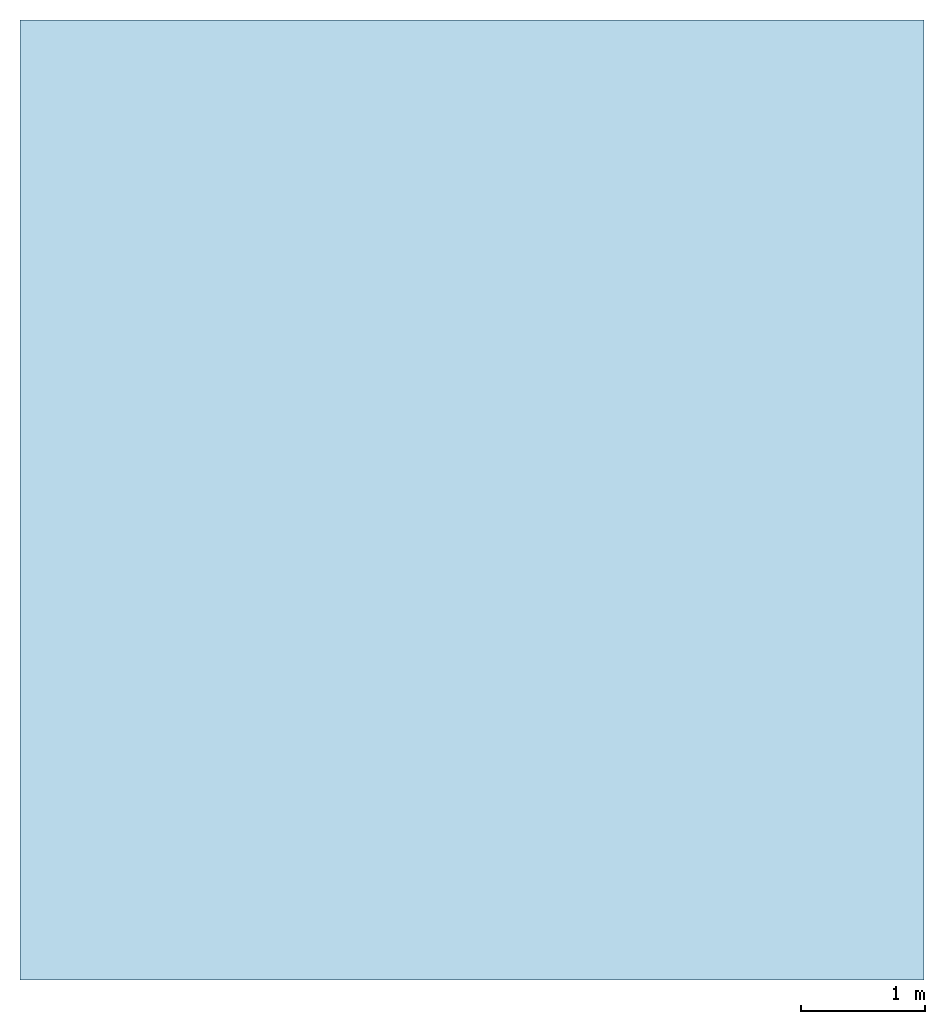
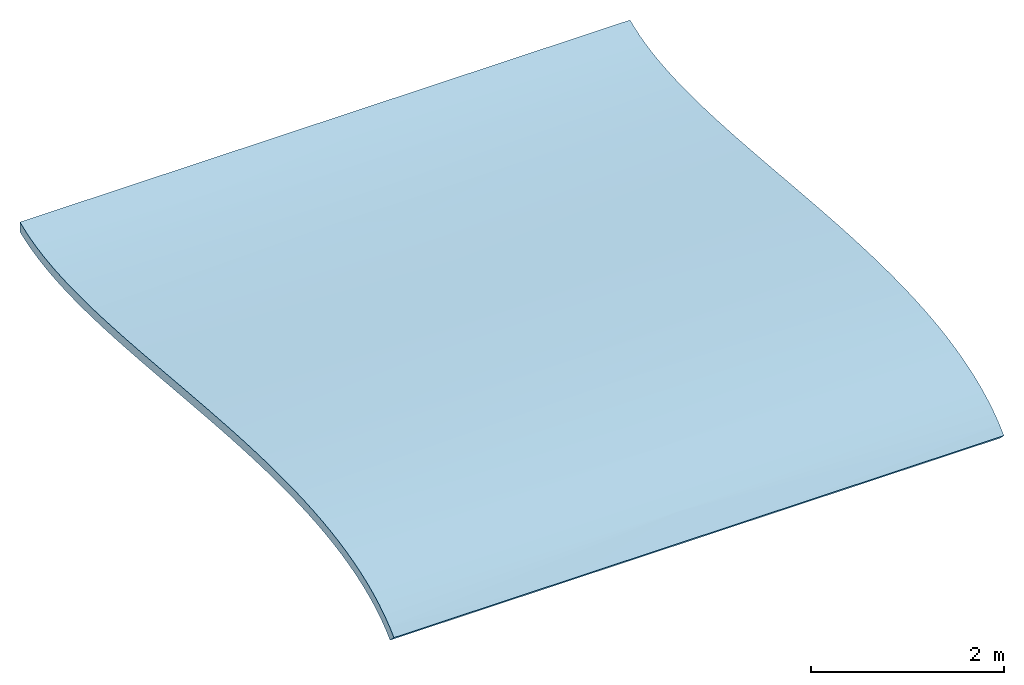
# One storey: 1 roof.
"""IFC2X3 building model written with IfcOpenShell, lengths in millimetres."""

from ifc_helpers import new_model, entity, si_unit, converted_unit, derived_unit, direction, frame, origin, place, context, subcontext, project, spatial, faceted_brep, material, element, save


model = new_model("IFC2X3")

# Units and contexts
model_context = context("Model", 3, precision=0.01, world=origin(), true_north=direction((6.12303176911189e-17, 1.0)))
body_context = subcontext(model_context, "Body", "Model", "MODEL_VIEW")
ifc_project = project(units=[si_unit("LENGTHUNIT", "METRE", prefix="MILLI"), si_unit("AREAUNIT", "SQUARE_METRE"), si_unit("VOLUMEUNIT", "CUBIC_METRE"), converted_unit("PLANEANGLEUNIT", "DEGREE", entity("IfcRatioMeasure", 0.0174532925199433), si_unit("PLANEANGLEUNIT", "RADIAN"), dimensions=[0, 0, 0, 0, 0, 0, 0]), si_unit("MASSUNIT", "GRAM", prefix="KILO"), si_unit("TIMEUNIT", "SECOND"), si_unit("FREQUENCYUNIT", "HERTZ"), si_unit("THERMODYNAMICTEMPERATUREUNIT", "DEGREE_CELSIUS"), derived_unit("THERMALTRANSMITTANCEUNIT", [(si_unit("MASSUNIT", "GRAM", prefix="KILO"), 1), (si_unit("THERMODYNAMICTEMPERATUREUNIT", "KELVIN"), -1), (si_unit("TIMEUNIT", "SECOND"), -3)]), derived_unit("VOLUMETRICFLOWRATEUNIT", [(si_unit("LENGTHUNIT", "METRE"), 3), (si_unit("TIMEUNIT", "SECOND"), -1)]), si_unit("ELECTRICCURRENTUNIT", "AMPERE"), si_unit("ELECTRICVOLTAGEUNIT", "VOLT"), si_unit("POWERUNIT", "WATT"), si_unit("FORCEUNIT", "NEWTON", prefix="KILO"), si_unit("ILLUMINANCEUNIT", "LUX"), si_unit("LUMINOUSFLUXUNIT", "LUMEN"), si_unit("LUMINOUSINTENSITYUNIT", "CANDELA"), derived_unit("USERDEFINED", [(si_unit("MASSUNIT", "GRAM", prefix="KILO"), -1), (si_unit("LENGTHUNIT", "METRE"), -2), (si_unit("TIMEUNIT", "SECOND"), 3), (si_unit("LUMINOUSFLUXUNIT", "LUMEN"), 1)]), derived_unit("LINEARVELOCITYUNIT", [(si_unit("LENGTHUNIT", "METRE"), 1), (si_unit("TIMEUNIT", "SECOND"), -1)]), si_unit("PRESSUREUNIT", "PASCAL"), derived_unit("USERDEFINED", [(si_unit("LENGTHUNIT", "METRE"), -2), (si_unit("MASSUNIT", "GRAM", prefix="KILO"), 1), (si_unit("TIMEUNIT", "SECOND"), -2)])], contexts=[model_context])

# Site, building, storey
site_placement = place(None, origin())
site = spatial("IfcSite", under=ifc_project, at=site_placement, CompositionType="ELEMENT")
building_placement = place(site_placement, origin())
building = spatial("IfcBuilding", under=site, at=building_placement, CompositionType="ELEMENT")
storey_placement = place(building_placement, frame((0.0, 0.0, 4000.0)))
storey = spatial("IfcBuildingStorey", under=building, at=storey_placement, Name="Level 1", CompositionType="ELEMENT", Elevation=4000.0)

# Roof
ifc_material = material(Name="Roofing, Standing Seam")
roof_placement = place(storey_placement, frame((6902.64559519151, -4029.3346626259, -2084.22174702)))
element("IfcRoof", 1, at=roof_placement, inside=storey, material=ifc_material, ShapeType="NOTDEFINED", context=body_context, shape_type="Brep", body=[
    faceted_brep([(7290.0, 5515.8367599344, 493.394615891995), (7290.0, 5326.79971379529, 507.350489187514), (7290.0, 5134.90988298857, 522.577872454902), (7290.0, 4940.56039759163, 538.776818324134), (7290.0, 4744.14438768187, 555.647379425186), (7290.0, 4546.05498333669, 572.889608388034), (7290.0, 4346.68531463349, 590.203557842651), (7290.0, 4146.42851164965, 607.289280419015), (7290.0, 3945.67770446258, 623.846828747097), (7290.0, 3744.82602314968, 639.576255456876), (7290.0, 3544.26659778834, 654.177613178324), (7290.0, 3344.39255845596, 667.350954541419), (7290.0, 3145.59703522994, 678.796332176132), (7290.0, 2948.27315818768, 688.213798712443), (7290.0, 2752.81405740656, 695.303406780325), (7290.0, 2559.61286296399, 699.765209009751), (7290.0, 2369.06270493737, 701.299258030699), (7290.0, 2181.55671340408, 699.605606473143), (7290.0, 1997.48801844154, 694.384306967057), (7290.0, 1817.24975012714, 685.335412142419), (7290.0, 1641.23503853826, 672.1589746292), (7290.0, 1469.83701375232, 654.555047057379), (7290.0, 1303.44880584671, 632.223682056929), (7290.0, 1142.46354489882, 604.864932257825), (7290.0, 987.274360986045, 572.178850290043), (7290.0, 838.274384185795, 533.865488783557), (7290.0, 695.856744575461, 489.624900368343), (7290.0, 560.414572232438, 439.157137674376), (7290.0, 432.340997234126, 382.16225333163), (7290.0, 312.029149657921, 318.340299970082), (7290.0, 199.87215958122, 247.391330219706), (7290.0, 96.2631570814181, 169.015396710476), (7290.0, 1.59527223591536, 82.9125520723694), (7290.0, 82.9125520723667, 1.59527223591644), (7290.0, 174.910983430362, 84.8106413142446), (7290.0, 276.870078001889, 160.732287026324), (7290.0, 388.608164668871, 229.627760435748), (7290.0, 509.856659043408, 291.700233714452), (7290.0, 640.265006553385, 347.128372768542), (7290.0, 779.417409593224, 396.093969562423), (7290.0, 926.852331926818, 438.797089949555), (7290.0, 1082.079622683, 475.46195964892), (7290.0, 1244.59347115748, 506.337245264513), (7290.0, 1413.8812661407, 531.693556891933), (7290.0, 1589.42918286418, 551.819949919396), (7290.0, 1770.72543261784, 567.020383280753), (7290.0, 1957.26196426142, 577.610566329318), (7290.0, 2148.53520002354, 583.915333002722), (7290.0, 2344.04620233902, 586.266539454875), (7290.0, 2543.30053061132, 585.001416438763), (7290.0, 2745.80794324389, 580.46130577549), (7290.0, 2951.08212696384, 572.990675875639), (7290.0, 3158.63987988746, 562.936400057024), (7290.0, 3368.00056105001, 550.646731588187), (7290.0, 3578.68943782287, 536.472643248029), (7290.0, 3790.23289787507, 520.765623469924), (7290.0, 4002.1573757589, 503.877174054427), (7290.0, 4213.99265493133, 486.159751629483), (7290.0, 4425.27404377407, 467.96738806927), (7290.0, 4635.53736724828, 449.6542625332), (7290.0, 4844.31869207961, 431.574600983515), (7290.0, 5051.15896875634, 414.08357482278), (7290.0, 5255.60368271807, 397.537233368033), (7290.0, 5457.19849128652, 382.291659210715), (7290.0, 5655.49034587235, 368.703392642995), (7290.0, 5850.03758452909, 357.13300124958), (7290.0, 6040.4044608883, 347.943144870431), (7290.0, 6226.1552790644, 341.496501200568), (7290.0, 6406.85837974509, 338.158011573538), (7290.0, 6582.10003525807, 338.302673420665), (7290.0, 6751.47451000516, 342.31103492595), (7290.0, 6914.58904090166, 350.575753809645), (7290.0, 7071.06630490577, 363.506025200245), (7290.0, 7220.54613217014, 381.535486437245), (7290.0, 7362.68547363244, 405.133111431908), (7290.0, 7497.15423732193, 434.818313729678), (7290.0, 7623.62222011881, 471.18003034358), (7290.0, 7741.72983927739, 514.896982003152), (7290.0, 7741.72983927739, 640.601924700541), (7290.0, 7642.66017244013, 599.491464015022), (7290.0, 7534.84076977431, 564.151723851747), (7290.0, 7418.66476135731, 534.282756840691), (7290.0, 7294.52527726654, 509.584615611828), (7290.0, 7162.81544757938, 489.757352795134), (7290.0, 7023.92840237325, 474.501021020584), (7290.0, 6878.25727172553, 463.515672918153), (7290.0, 6726.19518571363, 456.501361117816), (7290.0, 6568.13527441493, 453.158138249548), (7290.0, 6404.47066790685, 453.186056943324), (7290.0, 6235.59449626676, 456.285169829119), (7290.0, 6061.89988957208, 462.155529536909), (7290.0, 5883.77997790019, 470.497188696669), (7290.0, 5701.6278913285, 481.010199938372), (0.0, 174.910983430373, 84.8106413142446), (0.0, 82.912552072378, 1.59527223591644), (0.0, 1.59527223592673, 82.9125520723694), (0.0, 96.2631570814294, 169.015396710476), (0.0, 199.872159581231, 247.391330219706), (0.0, 312.029149657932, 318.340299970082), (0.0, 432.340997234137, 382.16225333163), (0.0, 560.41457223245, 439.157137674376), (0.0, 695.856744575472, 489.624900368343), (0.0, 838.274384185806, 533.865488783557), (0.0, 987.274360986057, 572.178850290043), (0.0, 1142.46354489883, 604.864932257825), (0.0, 1303.44880584672, 632.223682056929), (0.0, 1469.83701375233, 654.555047057379), (0.0, 1641.23503853827, 672.1589746292), (0.0, 1817.24975012715, 685.335412142419), (0.0, 1997.48801844155, 694.384306967057), (0.0, 2181.55671340409, 699.605606473143), (0.0, 2369.06270493738, 701.299258030699), (0.0, 2559.612862964, 699.765209009751), (0.0, 2752.81405740657, 695.303406780325), (0.0, 2948.27315818769, 688.213798712443), (0.0, 3145.59703522995, 678.796332176132), (0.0, 3344.39255845598, 667.350954541419), (0.0, 3544.26659778835, 654.177613178324), (0.0, 3744.82602314969, 639.576255456876), (0.0, 3945.67770446259, 623.846828747097), (0.0, 4146.42851164966, 607.289280419015), (0.0, 4346.6853146335, 590.203557842651), (0.0, 4546.0549833367, 572.889608388034), (0.0, 4744.14438768188, 555.647379425186), (0.0, 4940.56039759164, 538.776818324134), (0.0, 5134.90988298858, 522.577872454902), (0.0, 5326.79971379531, 507.350489187514), (0.0, 5515.83675993441, 493.394615891995), (0.0, 5701.62789132851, 481.010199938372), (0.0, 5883.7799779002, 470.497188696669), (0.0, 6061.89988957209, 462.155529536909), (0.0, 6235.59449626677, 456.285169829119), (0.0, 6404.47066790686, 453.186056943324), (0.0, 6568.13527441495, 453.158138249548), (0.0, 6726.19518571364, 456.501361117816), (0.0, 6878.25727172555, 463.515672918153), (0.0, 7023.92840237326, 474.501021020584), (0.0, 7162.8154475794, 489.757352795134), (0.0, 7294.52527726655, 509.584615611828), (0.0, 7418.66476135732, 534.282756840691), (0.0, 7534.84076977432, 564.151723851747), (0.0, 7642.66017244015, 599.491464015022), (0.0, 7741.7298392774, 640.601924700541), (0.0, 7741.7298392774, 514.896982003152), (0.0, 7623.62222011882, 471.18003034358), (0.0, 7497.15423732194, 434.818313729678), (0.0, 7362.68547363246, 405.133111431908), (0.0, 7220.54613217015, 381.535486437245), (0.0, 7071.06630490578, 363.506025200245), (0.0, 6914.58904090168, 350.575753809645), (0.0, 6751.47451000517, 342.31103492595), (0.0, 6582.10003525808, 338.302673420665), (0.0, 6406.8583797451, 338.158011573538), (0.0, 6226.15527906442, 341.496501200568), (0.0, 6040.40446088831, 347.943144870431), (0.0, 5850.0375845291, 357.13300124958), (0.0, 5655.49034587236, 368.703392642995), (0.0, 5457.19849128653, 382.291659210715), (0.0, 5255.60368271808, 397.537233368033), (0.0, 5051.15896875636, 414.08357482278), (0.0, 4844.31869207963, 431.574600983515), (0.0, 4635.53736724829, 449.654262533201), (0.0, 4425.27404377408, 467.96738806927), (0.0, 4213.99265493135, 486.159751629483), (0.0, 4002.15737575891, 503.877174054427), (0.0, 3790.23289787508, 520.765623469924), (0.0, 3578.68943782288, 536.472643248029), (0.0, 3368.00056105003, 550.646731588187), (0.0, 3158.63987988748, 562.936400057024), (0.0, 2951.08212696385, 572.990675875639), (0.0, 2745.80794324391, 580.46130577549), (0.0, 2543.30053061133, 585.001416438763), (0.0, 2344.04620233903, 586.266539454875), (0.0, 2148.53520002355, 583.915333002722), (0.0, 1957.26196426143, 577.610566329318), (0.0, 1770.72543261785, 567.020383280753), (0.0, 1589.42918286419, 551.819949919396), (0.0, 1413.88126614072, 531.693556891933), (0.0, 1244.59347115749, 506.337245264513), (0.0, 1082.07962268301, 475.46195964892), (0.0, 926.852331926829, 438.797089949555), (0.0, 779.417409593235, 396.093969562423), (0.0, 640.265006553396, 347.128372768542), (0.0, 509.856659043419, 291.700233714452), (0.0, 388.608164668882, 229.627760435748), (0.0, 276.870078001901, 160.732287026324), (3644.99993293393, 7094.24445769617, 481.576561905731), (4873.42643812675, 3553.80531263484, 653.512268049968), (4873.4264349205, 2378.07126114901, 701.297023002409), (4873.42644526128, 6885.34251186391, 463.946393367723), (3645.0, 6647.89036821082, 454.389609869361), (4833.14712739967, 2948.2731567139, 688.213798774734), (4866.99006258193, 437.319117905568, 384.571897066555), (2456.85285398539, 6878.2572394437, 463.515670978227), (5143.13104624073, 1728.68987856066, 679.281882891266), (5143.13108979598, 6320.65944870228, 454.370460977534), (3755.78478848222, 7477.77282685478, 548.552154853789), (4873.42644037187, 4155.97956112262, 606.485217518944), (4154.34922870835, 7741.72983927739, 640.601924700541), (2077.17461435418, 7741.7298392774, 640.601924700541), (4158.30513321711, 7293.47192435091, 509.402015403087), (2083.10604010014, 7357.56586274999, 521.306075659749), (3645.0, 5973.36851791904, 466.03619378561), (2879.75484514576, 6320.65944357094, 454.370461072072), (3645.0, 5038.01802242677, 530.574647113318), (4873.42644326935, 4753.53927521058, 554.833156981952), (3645.0, 4446.50560851197, 581.556365015466), (2456.85288603018, 4744.14438460476, 555.647379691955), (3645.0, 3845.23990030763, 631.833804182173), (3705.40861769169, 5515.83675357721, 493.394616340274), (2456.85288047229, 4146.42850943027, 607.289280605706), (2083.10611478902, 7589.81964531163, 581.119009704308), (3645.0, 3244.83541008503, 673.308385628513), (3645.0, 2089.06813226758, 697.454659397298), (3645.0, 2655.90665002507, 697.88153036414), (3645.0, 627.239153951746, 465.188162362641), (3645.0, 1385.99211138934, 643.999040856456), (2443.55129102401, 434.296109138398, 383.110638627745), (3561.38047398335, 254.906726379767, 283.775438586921), (4154.34866312986, 1.59527223592023, 82.9125520723689), (3705.40870996265, 987.274360445025, 572.178850163996), (2456.8528697884, 2369.06270397232, 701.299258030547), (2456.8528761003, 3544.26659613439, 654.177613293421), (2879.75477886344, 1728.68987835546, 679.28188287592), (2416.57356343063, 2938.91950082385, 688.606588632029), (2077.17433156493, 1.59527223592348, 82.9125520723689), (2063.72518347873, 82.9125520723753, 1.59527223591536), (4127.45036695744, 82.9125520723726, 1.59527223591482), (3644.9999788372, 852.129705162649, 418.214959644609), (3645.0, 5153.70916869194, 405.67006324816), (2527.73964691474, 1082.07964281491, 475.461963920434), (3645.0, 1328.42277286879, 519.687632279817), (4908.86982804358, 1057.38503155373, 470.13294026234), (3645.0, 4108.11524259923, 495.099966522061), (3645.0, 5753.2592804111, 362.643297370898), (3644.99968743525, 448.06389055526, 261.505584802579), (5014.79117722024, 224.654963164434, 123.664570221709), (2617.32967391422, 224.654968225618, 123.66457398959), (3645.0, 3473.20857833004, 543.773271701596), (4908.86981738276, 3126.14787253684, 564.65996733546), (4762.26032903465, 640.265053007929, 347.128390738387), (3645.0, 2848.12943127412, 577.070656466003), (3645.0, 1863.37025447432, 572.871646434587), (4908.86982958123, 1561.66752542892, 549.01395190956), (2527.7396350338, 3158.6398826696, 562.936399907201), (3645.0, 2361.25902041309, 586.295229736864), (2527.73965785907, 1589.42919219338, 551.819950839825), (4908.86981441765, 3757.21313088441, 523.301229060313), (2063.72490335407, 7741.7298392774, 514.896982003151), (4127.44980670813, 7741.72983927739, 514.896982003152), (2617.32977762103, 7561.40952052499, 452.124720828273), (2381.13004015164, 661.396844690464, 355.183267158089), (4908.86980929022, 5425.97285046491, 384.568668097563), (4908.86980800386, 6011.01621100343, 349.20466139658), (3645.0, 7146.70272357588, 371.855063208914), (3645.0, 6317.1639638328, 339.415474239967), (2538.13047883346, 7350.35431830495, 402.796681929502), (4770.28662975967, 7430.89904212718, 419.179976333053), (2527.73962910166, 3790.23289988587, 520.76562331465), (2527.73961877477, 5457.19849223257, 382.291659142245), (2527.73961617756, 6040.40446161021, 347.943144840199), (3645.0, 4653.78727024394, 448.065185016509), (3645.0, 6765.93576440861, 342.855882859757)], [[[0, 1, 2, 3, 4, 5, 6, 7, 8, 9, 10, 11, 12, 13, 14, 15, 16, 17, 18, 19, 20, 21, 22, 23, 24, 25, 26, 27, 28, 29, 30, 31, 32, 33, 34, 35, 36, 37, 38, 39, 40, 41, 42, 43, 44, 45, 46, 47, 48, 49, 50, 51, 52, 53, 54, 55, 56, 57, 58, 59, 60, 61, 62, 63, 64, 65, 66, 67, 68, 69, 70, 71, 72, 73, 74, 75, 76, 77, 78, 79, 80, 81, 82, 83, 84, 85, 86, 87, 88, 89, 90, 91, 92]], [[93, 94, 95, 96, 97, 98, 99, 100, 101, 102, 103, 104, 105, 106, 107, 108, 109, 110, 111, 112, 113, 114, 115, 116, 117, 118, 119, 120, 121, 122, 123, 124, 125, 126, 127, 128, 129, 130, 131, 132, 133, 134, 135, 136, 137, 138, 139, 140, 141, 142, 143, 144, 145, 146, 147, 148, 149, 150, 151, 152, 153, 154, 155, 156, 157, 158, 159, 160, 161, 162, 163, 164, 165, 166, 167, 168, 169, 170, 171, 172, 173, 174, 175, 176, 177, 178, 179, 180, 181, 182, 183, 184, 185]], [[186, 84, 83]], [[10, 9, 187]], [[16, 15, 188]], [[189, 190, 86]], [[87, 86, 190]], [[191, 13, 12]], [[28, 27, 192]], [[193, 190, 189]], [[19, 18, 194]], [[88, 195, 89]], [[80, 196, 81]], [[7, 6, 197]], [[190, 134, 133]], [[196, 79, 198]], [[186, 137, 136]], [[198, 79, 78]], [[142, 141, 199]], [[200, 186, 83]], [[201, 186, 200]], [[91, 202, 92]], [[138, 201, 139]], [[202, 195, 203]], [[204, 3, 2]], [[5, 205, 206]], [[206, 6, 5]], [[206, 205, 207]], [[208, 8, 197]], [[202, 91, 90]], [[0, 92, 209]], [[128, 127, 209]], [[1, 209, 204]], [[92, 202, 209]], [[2, 1, 204]], [[202, 90, 195]], [[197, 210, 208]], [[204, 125, 124]], [[80, 79, 196]], [[211, 199, 141]], [[88, 87, 195]], [[4, 3, 205]], [[140, 211, 141]], [[211, 140, 139]], [[85, 84, 189]], [[201, 196, 211]], [[206, 122, 121]], [[193, 186, 136]], [[137, 201, 138]], [[208, 119, 118]], [[202, 130, 129]], [[135, 193, 136]], [[193, 135, 134]], [[212, 116, 115]], [[213, 110, 109]], [[133, 203, 190]], [[214, 113, 112]], [[203, 133, 132]], [[215, 101, 100]], [[131, 203, 132]], [[131, 130, 203]], [[216, 106, 105]], [[196, 200, 81]], [[129, 128, 202]], [[128, 209, 202]], [[217, 99, 98]], [[201, 211, 139]], [[200, 82, 81]], [[126, 209, 127]], [[0, 209, 1]], [[126, 125, 204]], [[186, 201, 137]], [[196, 201, 200]], [[207, 204, 124]], [[207, 124, 123]], [[218, 97, 96]], [[211, 196, 198]], [[122, 207, 123]], [[121, 210, 206]], [[29, 218, 30]], [[121, 120, 210]], [[218, 219, 31]], [[8, 208, 9]], [[15, 14, 214]], [[29, 28, 192]], [[215, 192, 27]], [[188, 213, 17]], [[18, 17, 213]], [[99, 217, 100]], [[102, 215, 220]], [[188, 221, 213]], [[215, 217, 192]], [[19, 194, 20]], [[212, 11, 187]], [[222, 212, 187]], [[12, 212, 191]], [[211, 198, 199]], [[11, 212, 12]], [[214, 14, 191]], [[223, 216, 194]], [[215, 27, 26]], [[214, 191, 224]], [[13, 191, 14]], [[31, 30, 218]], [[219, 218, 225]], [[208, 187, 9]], [[212, 222, 116]], [[218, 29, 192]], [[11, 10, 187]], [[219, 32, 31]], [[96, 95, 225]], [[216, 22, 21]], [[223, 194, 213]], [[21, 20, 194]], [[24, 23, 220]], [[104, 103, 220]], [[25, 220, 215]], [[213, 194, 18]], [[115, 114, 224]], [[23, 216, 220]], [[106, 216, 223]], [[215, 26, 25]], [[216, 21, 194]], [[214, 224, 113]], [[24, 220, 25]], [[102, 220, 103]], [[96, 225, 218]], [[222, 208, 118]], [[117, 222, 118]], [[186, 193, 189]], [[82, 200, 83]], [[222, 117, 116]], [[224, 191, 212]], [[86, 85, 189]], [[186, 189, 84]], [[224, 212, 115]], [[190, 193, 134]], [[114, 113, 224]], [[112, 221, 214]], [[204, 205, 3]], [[206, 207, 122]], [[221, 112, 111]], [[221, 111, 110]], [[130, 202, 203]], [[190, 195, 87]], [[109, 223, 213]], [[5, 4, 205]], [[109, 108, 223]], [[204, 207, 205]], [[107, 223, 108]], [[107, 106, 223]], [[203, 195, 190]], [[105, 104, 216]], [[104, 220, 216]], [[208, 210, 119]], [[206, 210, 197]], [[126, 204, 209]], [[102, 101, 215]], [[214, 221, 188]], [[8, 7, 197]], [[217, 215, 100]], [[217, 218, 192]], [[17, 16, 188]], [[214, 188, 15]], [[217, 98, 218]], [[213, 221, 110]], [[22, 216, 23]], [[206, 197, 6]], [[98, 97, 218]], [[90, 89, 195]], [[208, 222, 187]], [[120, 119, 210]], [[32, 219, 225, 95, 94, 226, 227, 33]], [[39, 228, 40]], [[229, 159, 158]], [[230, 231, 232]], [[233, 164, 163]], [[231, 42, 232]], [[234, 156, 155]], [[43, 42, 231]], [[235, 236, 237]], [[238, 167, 166]], [[52, 51, 239]], [[236, 235, 36]], [[240, 228, 39]], [[241, 170, 169]], [[242, 175, 174]], [[240, 37, 235]], [[240, 38, 37]], [[44, 43, 243]], [[242, 45, 243]], [[241, 51, 50]], [[239, 244, 238]], [[239, 238, 53]], [[238, 54, 53]], [[242, 46, 45]], [[48, 47, 245]], [[49, 245, 241]], [[47, 242, 245]], [[241, 50, 49]], [[242, 243, 246]], [[56, 247, 233]], [[228, 181, 180]], [[237, 226, 93]], [[184, 237, 185]], [[184, 183, 235]], [[41, 40, 232]], [[248, 249, 250]], [[236, 35, 34]], [[231, 178, 177]], [[55, 54, 247]], [[33, 236, 34]], [[251, 240, 235]], [[46, 242, 47]], [[183, 251, 235]], [[182, 181, 251]], [[63, 62, 252]], [[235, 37, 36]], [[180, 230, 228]], [[66, 65, 253]], [[180, 179, 230]], [[185, 237, 93]], [[230, 179, 178]], [[177, 246, 231]], [[254, 148, 147]], [[57, 233, 58]], [[246, 177, 176]], [[246, 176, 175]], [[255, 153, 152]], [[248, 144, 143]], [[249, 77, 76]], [[174, 173, 242]], [[242, 173, 245]], [[241, 245, 171]], [[146, 145, 256]], [[235, 237, 184]], [[172, 171, 245]], [[171, 170, 241]], [[254, 257, 73]], [[250, 257, 256]], [[241, 169, 244]], [[75, 74, 257]], [[169, 168, 244]], [[227, 237, 236, 33]], [[168, 167, 244]], [[74, 73, 257]], [[258, 238, 166]], [[62, 61, 229]], [[94, 93, 226]], [[259, 234, 252]], [[234, 253, 65]], [[255, 260, 153]], [[234, 64, 252]], [[67, 66, 253]], [[65, 64, 234]], [[233, 57, 56]], [[58, 261, 59]], [[261, 229, 60]], [[233, 261, 58]], [[61, 60, 229]], [[255, 67, 253]], [[237, 227, 226]], [[254, 73, 72]], [[64, 63, 252]], [[76, 75, 257]], [[234, 259, 156]], [[229, 259, 252]], [[257, 250, 249]], [[229, 252, 62]], [[250, 145, 144]], [[255, 68, 67]], [[70, 262, 71]], [[151, 150, 262]], [[70, 69, 262]], [[71, 262, 254]], [[238, 247, 54]], [[233, 258, 164]], [[69, 255, 262]], [[56, 55, 247]], [[254, 72, 71]], [[255, 253, 260]], [[238, 258, 247]], [[234, 260, 253]], [[250, 144, 248]], [[258, 166, 165]], [[258, 165, 164]], [[233, 163, 162]], [[228, 230, 232]], [[146, 256, 147]], [[162, 261, 233]], [[250, 256, 145]], [[261, 160, 229]], [[261, 161, 160]], [[42, 41, 232]], [[228, 232, 40]], [[160, 159, 229]], [[158, 259, 229]], [[241, 244, 239]], [[48, 245, 49]], [[158, 157, 259]], [[173, 172, 245]], [[259, 157, 156]], [[231, 230, 178]], [[155, 260, 234]], [[155, 154, 260]], [[53, 52, 239]], [[241, 239, 51]], [[153, 260, 154]], [[151, 255, 152]], [[231, 243, 43]], [[242, 246, 175]], [[255, 151, 262]], [[231, 246, 243]], [[254, 262, 149]], [[149, 262, 150]], [[228, 240, 251]], [[38, 240, 39]], [[254, 149, 148]], [[254, 147, 256]], [[162, 161, 261]], [[183, 182, 251]], [[257, 249, 76]], [[228, 251, 181]], [[256, 257, 254]], [[45, 44, 243]], [[68, 255, 69]], [[238, 244, 167]], [[59, 261, 60]], [[258, 233, 247]], [[36, 35, 236]], [[78, 77, 249, 248, 143, 142, 199, 198]]]),
])

save(model, "model.ifc")
